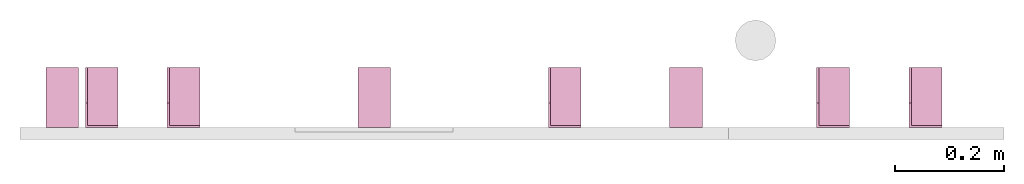
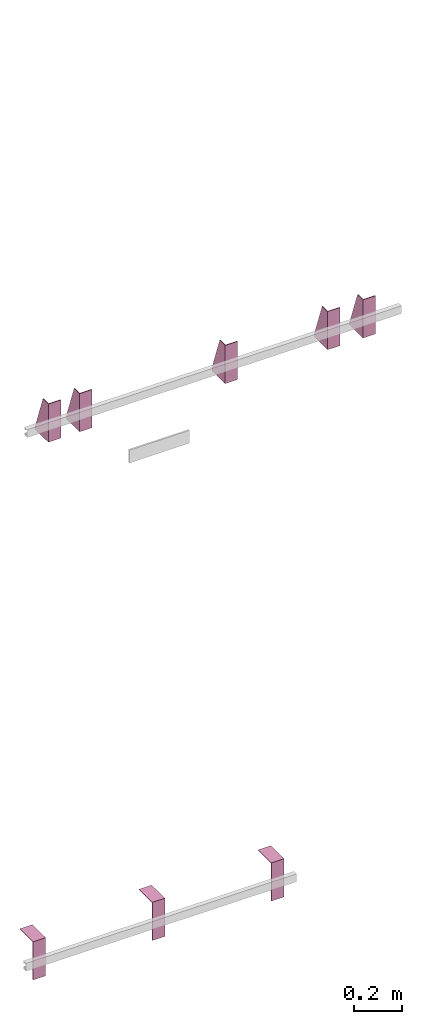
# One storey, part 3 of 3: 8 transport elements.
"""IFC4 building model written with IfcOpenShell, lengths in millimetres."""

from ifc_helpers import new_model, entity, si_unit, converted_unit, frame, origin_with_axes, place, context, subcontext, project, spatial, faceted_brep, element, save


model = new_model("IFC4")

# Units and contexts
context_of_model = context(None, 3, precision=0.01, world=origin_with_axes())
sub_context_1 = subcontext(context_of_model, None, None, "MODEL_VIEW")
sub_context_2 = subcontext(context_of_model, None, None, "MODEL_VIEW")
sub_context_3 = subcontext(context_of_model, None, None, "MODEL_VIEW")
sub_context_4 = subcontext(context_of_model, None, None, "MODEL_VIEW")
sub_context_5 = subcontext(context_of_model, None, None, "MODEL_VIEW")
sub_context_6 = subcontext(context_of_model, None, None, "MODEL_VIEW")
sub_context_7 = subcontext(context_of_model, None, None, "MODEL_VIEW")
sub_context_8 = subcontext(context_of_model, None, None, "MODEL_VIEW")
ifc_project = project(units=[converted_unit("PLANEANGLEUNIT", "degree", entity("IfcPlaneAngleMeasure", 0.017453292519943), si_unit("PLANEANGLEUNIT", "RADIAN"), dimensions=[0, 0, 0, 0, 0, 0, 0]), si_unit("LENGTHUNIT", "METRE", prefix="MILLI"), si_unit("MASSUNIT", "GRAM", prefix="KILO"), converted_unit("TIMEUNIT", "year", entity("IfcTimeMeasure", 31557600.0), si_unit("TIMEUNIT", "SECOND"), dimensions=[0, 0, 1, 0, 0, 0, 0]), si_unit("THERMODYNAMICTEMPERATUREUNIT", "DEGREE_CELSIUS"), si_unit("AREAUNIT", "SQUARE_METRE"), si_unit("FORCEUNIT", "NEWTON"), si_unit("VOLUMEUNIT", "CUBIC_METRE"), si_unit("PRESSUREUNIT", "PASCAL"), si_unit("SOLIDANGLEUNIT", "STERADIAN")], contexts=[context_of_model])

# Site, building, storey
site = spatial("IfcSite", under=ifc_project)
building = spatial("IfcBuilding", under=site, Name="Document")
placement = place(None, origin_with_axes())
storey_placement = place(placement, frame((0.0, 0.0, -11730.0), z_axis=(0.0, 0.0, 1.0), x_axis=(1.0, 0.0, 0.0)))
storey = spatial("IfcBuildingStorey", under=building, at=storey_placement, Name="P2", Elevation=-11730.0)

# Transport elements
transport_element_1_placement = place(storey_placement, frame((265.0, 0.0, 2580.0), z_axis=(0.0, 0.0, 1.0), x_axis=(1.0, 0.0, 0.0)))
element("IfcTransportElement", 1, at=transport_element_1_placement, inside=storey, PredefinedType="ELEVATOR", context=sub_context_1, shape_type="Brep", body=[
    faceted_brep([(-30.0, 4.0, -93.0), (-30.0, 4.0, 97.0), (-30.0, 45.0, 97.0), (-30.0, 110.0, -82.0), (-30.0, 110.0, -93.0), (-26.0, 4.0, -93.0), (-26.0, 110.0, -93.0), (-26.0, 110.0, -82.0), (-26.0, 45.0, 97.0), (-26.0, 4.0, 97.0)], [[[0, 1, 2, 3, 4]], [[5, 6, 7, 8, 9]], [[5, 0, 4, 6]], [[6, 4, 3, 7]], [[7, 3, 2, 8]], [[8, 2, 1, 9]], [[9, 1, 0, 5]]]),
    faceted_brep([(-30.0, 0.0, -97.0), (-30.0, 0.0, 97.0), (-30.0, 4.0, 97.0), (-30.0, 4.0, -93.0), (-30.0, 110.0, -93.0), (-30.0, 110.0, -97.0), (30.0, 110.0, -97.0), (30.0, 110.0, -93.0), (30.0, 4.0, -93.0), (30.0, 4.0, 97.0), (30.0, 0.0, 97.0), (30.0, 0.0, -97.0)], [[[0, 1, 2, 3, 4, 5]], [[6, 7, 8, 9, 10, 11]], [[11, 10, 1, 0]], [[2, 9, 8, 3]], [[4, 7, 6, 5]], [[5, 6, 11, 0]], [[8, 7, 4, 3]], [[10, 9, 2, 1]]]),
])
transport_element_2_placement = place(storey_placement, frame((415.0, 0.0, 2580.0), z_axis=(0.0, 0.0, 1.0), x_axis=(1.0, 0.0, 0.0)))
element("IfcTransportElement", 2, at=transport_element_2_placement, inside=storey, PredefinedType="ELEVATOR", context=sub_context_2, shape_type="Brep", body=[
    faceted_brep([(-30.0, 0.0, -97.0), (-30.0, 0.0, 97.0), (-30.0, 4.0, 97.0), (-30.0, 4.0, -93.0), (-30.0, 110.0, -93.0), (-30.0, 110.0, -97.0), (30.0, 110.0, -97.0), (30.0, 110.0, -93.0), (30.0, 4.0, -93.0), (30.0, 4.0, 97.0), (30.0, 0.0, 97.0), (30.0, 0.0, -97.0)], [[[0, 1, 2, 3, 4, 5]], [[6, 7, 8, 9, 10, 11]], [[11, 10, 1, 0]], [[2, 9, 8, 3]], [[4, 7, 6, 5]], [[5, 6, 11, 0]], [[8, 7, 4, 3]], [[10, 9, 2, 1]]]),
    faceted_brep([(-30.0, 4.0, -93.0), (-30.0, 4.0, 97.0), (-30.0, 45.0, 97.0), (-30.0, 110.0, -82.0), (-30.0, 110.0, -93.0), (-26.0, 4.0, -93.0), (-26.0, 110.0, -93.0), (-26.0, 110.0, -82.0), (-26.0, 45.0, 97.0), (-26.0, 4.0, 97.0)], [[[0, 1, 2, 3, 4]], [[5, 6, 7, 8, 9]], [[5, 0, 4, 6]], [[6, 4, 3, 7]], [[7, 3, 2, 8]], [[8, 2, 1, 9]], [[9, 1, 0, 5]]]),
])
transport_element_3_placement = place(storey_placement, frame((1115.0, 0.0, 2580.0), z_axis=(0.0, 0.0, 1.0), x_axis=(1.0, 0.0, 0.0)))
element("IfcTransportElement", 3, at=transport_element_3_placement, inside=storey, PredefinedType="ELEVATOR", context=sub_context_3, shape_type="Brep", body=[
    faceted_brep([(-30.0, 0.0, -97.0), (-30.0, 0.0, 97.0), (-30.0, 4.0, 97.0), (-30.0, 4.0, -93.0), (-30.0, 110.0, -93.0), (-30.0, 110.0, -97.0), (30.0, 110.0, -97.0), (30.0, 110.0, -93.0), (30.0, 4.0, -93.0), (30.0, 4.0, 97.0), (30.0, 0.0, 97.0), (30.0, 0.0, -97.0)], [[[0, 1, 2, 3, 4, 5]], [[6, 7, 8, 9, 10, 11]], [[11, 10, 1, 0]], [[2, 9, 8, 3]], [[4, 7, 6, 5]], [[5, 6, 11, 0]], [[8, 7, 4, 3]], [[10, 9, 2, 1]]]),
    faceted_brep([(-30.0, 4.0, -93.0), (-30.0, 4.0, 97.0), (-30.0, 45.0, 97.0), (-30.0, 110.0, -82.0), (-30.0, 110.0, -93.0), (-26.0, 4.0, -93.0), (-26.0, 110.0, -93.0), (-26.0, 110.0, -82.0), (-26.0, 45.0, 97.0), (-26.0, 4.0, 97.0)], [[[0, 1, 2, 3, 4]], [[5, 6, 7, 8, 9]], [[5, 0, 4, 6]], [[6, 4, 3, 7]], [[7, 3, 2, 8]], [[8, 2, 1, 9]], [[9, 1, 0, 5]]]),
])
transport_element_4_placement = place(storey_placement, frame((1607.0, 0.0, 2580.0), z_axis=(0.0, 0.0, 1.0), x_axis=(1.0, 0.0, 0.0)))
element("IfcTransportElement", 4, at=transport_element_4_placement, inside=storey, PredefinedType="ELEVATOR", context=sub_context_4, shape_type="Brep", body=[
    faceted_brep([(-30.0, 4.0, -93.0), (-30.0, 4.0, 97.0), (-30.0, 45.0, 97.0), (-30.0, 110.0, -82.0), (-30.0, 110.0, -93.0), (-26.0, 4.0, -93.0), (-26.0, 110.0, -93.0), (-26.0, 110.0, -82.0), (-26.0, 45.0, 97.0), (-26.0, 4.0, 97.0)], [[[0, 1, 2, 3, 4]], [[5, 6, 7, 8, 9]], [[5, 0, 4, 6]], [[6, 4, 3, 7]], [[7, 3, 2, 8]], [[8, 2, 1, 9]], [[9, 1, 0, 5]]]),
    faceted_brep([(-30.0, 0.0, -97.0), (-30.0, 0.0, 97.0), (-30.0, 4.0, 97.0), (-30.0, 4.0, -93.0), (-30.0, 110.0, -93.0), (-30.0, 110.0, -97.0), (30.0, 110.0, -97.0), (30.0, 110.0, -93.0), (30.0, 4.0, -93.0), (30.0, 4.0, 97.0), (30.0, 0.0, 97.0), (30.0, 0.0, -97.0)], [[[0, 1, 2, 3, 4, 5]], [[6, 7, 8, 9, 10, 11]], [[11, 10, 1, 0]], [[2, 9, 8, 3]], [[4, 7, 6, 5]], [[5, 6, 11, 0]], [[8, 7, 4, 3]], [[10, 9, 2, 1]]]),
])
transport_element_5_placement = place(storey_placement, frame((1777.0, 0.0, 2580.0), z_axis=(0.0, 0.0, 1.0), x_axis=(1.0, 0.0, 0.0)))
element("IfcTransportElement", 5, at=transport_element_5_placement, inside=storey, PredefinedType="ELEVATOR", context=sub_context_5, shape_type="Brep", body=[
    faceted_brep([(-30.0, 0.0, -97.0), (-30.0, 0.0, 97.0), (-30.0, 4.0, 97.0), (-30.0, 4.0, -93.0), (-30.0, 110.0, -93.0), (-30.0, 110.0, -97.0), (30.0, 110.0, -97.0), (30.0, 110.0, -93.0), (30.0, 4.0, -93.0), (30.0, 4.0, 97.0), (30.0, 0.0, 97.0), (30.0, 0.0, -97.0)], [[[0, 1, 2, 3, 4, 5]], [[6, 7, 8, 9, 10, 11]], [[11, 10, 1, 0]], [[2, 9, 8, 3]], [[4, 7, 6, 5]], [[5, 6, 11, 0]], [[8, 7, 4, 3]], [[10, 9, 2, 1]]]),
    faceted_brep([(-30.0, 4.0, -93.0), (-30.0, 4.0, 97.0), (-30.0, 45.0, 97.0), (-30.0, 110.0, -82.0), (-30.0, 110.0, -93.0), (-26.0, 4.0, -93.0), (-26.0, 110.0, -93.0), (-26.0, 110.0, -82.0), (-26.0, 45.0, 97.0), (-26.0, 4.0, 97.0)], [[[0, 1, 2, 3, 4]], [[5, 6, 7, 8, 9]], [[5, 0, 4, 6]], [[6, 4, 3, 7]], [[7, 3, 2, 8]], [[8, 2, 1, 9]], [[9, 1, 0, 5]]]),
])
transport_element_6_placement = place(storey_placement, frame((1337.5, 0.0, -30.0), z_axis=(0.0, 0.0, -1.0), x_axis=(-1.0, 0.0, 0.0)))
element("IfcTransportElement", 6, at=transport_element_6_placement, inside=storey, PredefinedType="ELEVATOR", context=sub_context_6, shape_type="Brep", body=[
    faceted_brep([(30.0, 0.0, 0.0), (30.0, 110.0, 0.0), (30.0, 110.0, 4.0), (30.0, 4.0, 4.0), (30.0, 4.0, 194.0), (30.0, 0.0, 194.0), (-30.0, 4.0, 194.0), (-30.0, 4.0, 4.0), (-30.0, 110.0, 4.0), (-30.0, 110.0, 0.0), (-30.0, 0.0, 0.0), (-30.0, 0.0, 194.0)], [[[0, 1, 2, 3, 4, 5]], [[6, 7, 8, 9, 10, 11]], [[11, 10, 0, 5]], [[3, 7, 6, 4]], [[1, 9, 8, 2]], [[4, 6, 11, 5]], [[10, 9, 1, 0]], [[2, 8, 7, 3]]]),
    faceted_brep([(-30.0, 4.0, 4.0), (-30.0, 4.0, 194.0), (-30.0, 45.0, 194.0), (-30.0, 110.0, 15.0), (-30.0, 110.0, 4.0), (-26.0, 4.0, 4.0), (-26.0, 110.0, 4.0), (-26.0, 110.0, 15.0), (-26.0, 45.0, 194.0), (-26.0, 4.0, 194.0)], [[[0, 1, 2, 3, 4]], [[5, 6, 7, 8, 9]], [[5, 0, 4, 6]], [[6, 4, 3, 7]], [[7, 3, 2, 8]], [[8, 2, 1, 9]], [[9, 1, 0, 5]]]),
])
transport_element_7_placement = place(storey_placement, frame((765.0, 0.0, -30.0), z_axis=(0.0, 0.0, -1.0), x_axis=(-1.0, 0.0, 0.0)))
element("IfcTransportElement", 7, at=transport_element_7_placement, inside=storey, PredefinedType="ELEVATOR", context=sub_context_7, shape_type="Brep", body=[
    faceted_brep([(30.0, 0.0, 0.0), (30.0, 110.0, 0.0), (30.0, 110.0, 4.0), (30.0, 4.0, 4.0), (30.0, 4.0, 194.0), (30.0, 0.0, 194.0), (-30.0, 4.0, 194.0), (-30.0, 4.0, 4.0), (-30.0, 110.0, 4.0), (-30.0, 110.0, 0.0), (-30.0, 0.0, 0.0), (-30.0, 0.0, 194.0)], [[[0, 1, 2, 3, 4, 5]], [[6, 7, 8, 9, 10, 11]], [[11, 10, 0, 5]], [[3, 7, 6, 4]], [[1, 9, 8, 2]], [[4, 6, 11, 5]], [[10, 9, 1, 0]], [[2, 8, 7, 3]]]),
    faceted_brep([(-30.0, 4.0, 4.0), (-30.0, 4.0, 194.0), (-30.0, 45.0, 194.0), (-30.0, 110.0, 15.0), (-30.0, 110.0, 4.0), (-26.0, 4.0, 4.0), (-26.0, 110.0, 4.0), (-26.0, 110.0, 15.0), (-26.0, 45.0, 194.0), (-26.0, 4.0, 194.0)], [[[0, 1, 2, 3, 4]], [[5, 6, 7, 8, 9]], [[5, 0, 4, 6]], [[6, 4, 3, 7]], [[7, 3, 2, 8]], [[8, 2, 1, 9]], [[9, 1, 0, 5]]]),
])
transport_element_8_placement = place(storey_placement, frame((192.5, 0.0, -30.0), z_axis=(0.0, 0.0, -1.0), x_axis=(-1.0, 0.0, 0.0)))
element("IfcTransportElement", 8, at=transport_element_8_placement, inside=storey, PredefinedType="ELEVATOR", context=sub_context_8, shape_type="Brep", body=[
    faceted_brep([(-30.0, 4.0, 4.0), (-30.0, 4.0, 194.0), (-30.0, 45.0, 194.0), (-30.0, 110.0, 15.0), (-30.0, 110.0, 4.0), (-26.0, 4.0, 4.0), (-26.0, 110.0, 4.0), (-26.0, 110.0, 15.0), (-26.0, 45.0, 194.0), (-26.0, 4.0, 194.0)], [[[0, 1, 2, 3, 4]], [[5, 6, 7, 8, 9]], [[5, 0, 4, 6]], [[6, 4, 3, 7]], [[7, 3, 2, 8]], [[8, 2, 1, 9]], [[9, 1, 0, 5]]]),
    faceted_brep([(30.0, 0.0, 0.0), (30.0, 110.0, 0.0), (30.0, 110.0, 4.0), (30.0, 4.0, 4.0), (30.0, 4.0, 194.0), (30.0, 0.0, 194.0), (-30.0, 4.0, 194.0), (-30.0, 4.0, 4.0), (-30.0, 110.0, 4.0), (-30.0, 110.0, 0.0), (-30.0, 0.0, 0.0), (-30.0, 0.0, 194.0)], [[[0, 1, 2, 3, 4, 5]], [[6, 7, 8, 9, 10, 11]], [[11, 10, 0, 5]], [[3, 7, 6, 4]], [[1, 9, 8, 2]], [[4, 6, 11, 5]], [[10, 9, 1, 0]], [[2, 8, 7, 3]]]),
])

save(model, "model.ifc")
